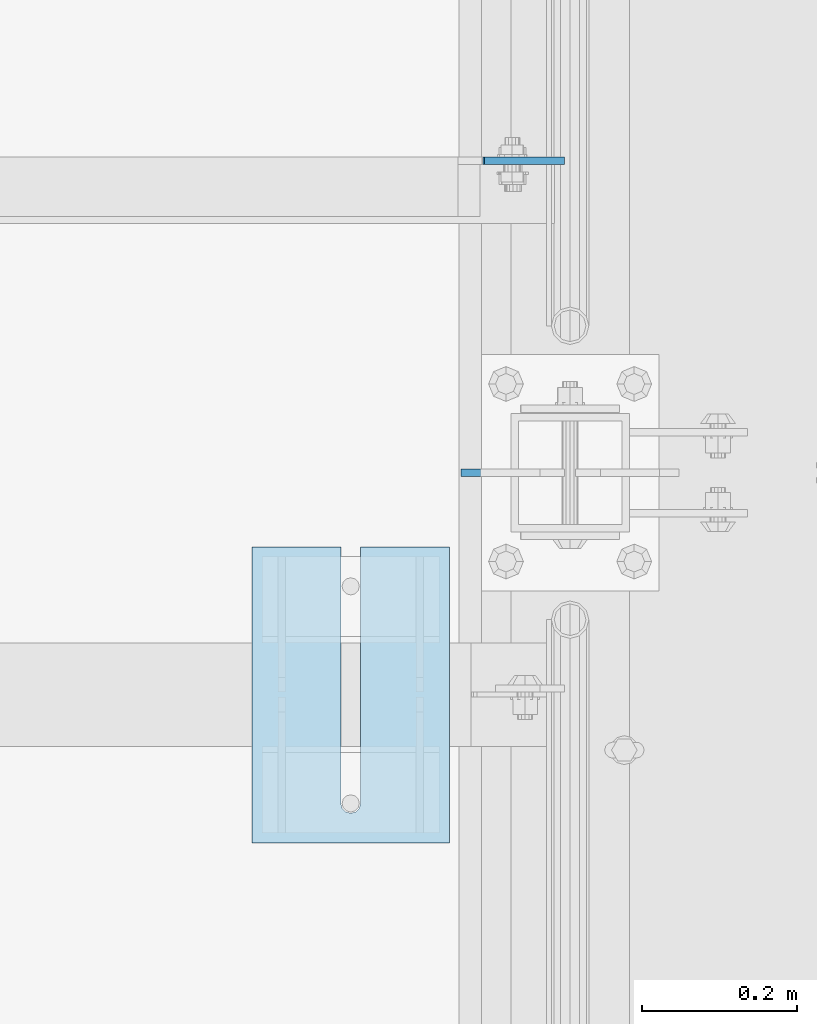
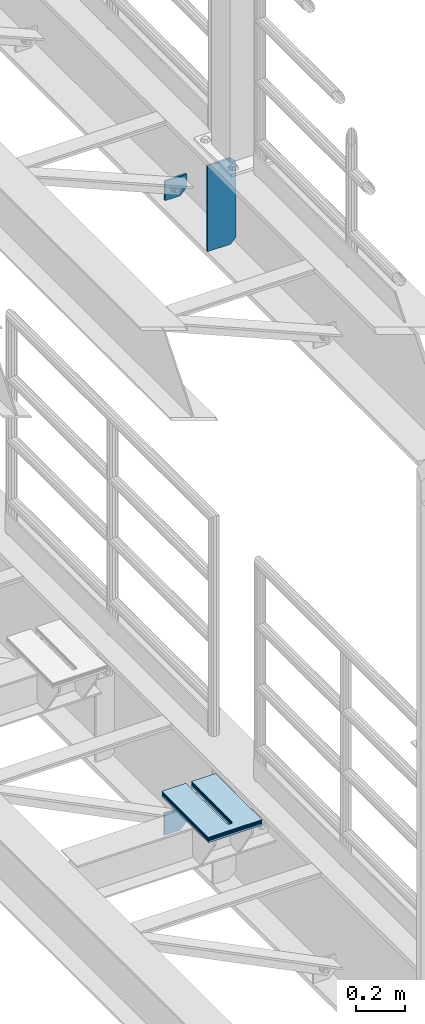
# One storey, part 1741 of 1876: 9 plates, 8 elements without a shape of their own.
"""IFC2X3 building model written with IfcOpenShell, lengths in millimetres."""

from ifc_helpers import new_model, si_unit, frame, origin_with_axes, place, context, subcontext, project, spatial, faceted_brep, material, type_object, element, aggregate, save


model = new_model("IFC2X3")

# Units and contexts
model_context = context("Model", 3, precision=1e-05, world=origin_with_axes())
body_context = subcontext(model_context, "Body", "Model", "MODEL_VIEW")
ifc_project = project(units=[si_unit("LENGTHUNIT", "METRE", prefix="MILLI"), si_unit("AREAUNIT", "SQUARE_METRE"), si_unit("VOLUMEUNIT", "CUBIC_METRE"), si_unit("MASSUNIT", "GRAM", prefix="KILO"), si_unit("TIMEUNIT", "SECOND"), si_unit("PLANEANGLEUNIT", "RADIAN"), si_unit("SOLIDANGLEUNIT", "STERADIAN"), si_unit("THERMODYNAMICTEMPERATUREUNIT", "DEGREE_CELSIUS"), si_unit("LUMINOUSINTENSITYUNIT", "LUMEN")], contexts=[model_context])

# Site, building, storey
site_placement = place(None, origin_with_axes())
site = spatial("IfcSite", under=ifc_project, at=site_placement, CompositionType="ELEMENT")
building_placement = place(site_placement, origin_with_axes())
building = spatial("IfcBuilding", under=site, at=building_placement, Name="Undefined", CompositionType="ELEMENT")
storey_placement = place(building_placement, origin_with_axes())
storey = spatial("IfcBuildingStorey", under=building, at=storey_placement, Name="Undefined", CompositionType="ELEMENT", Elevation=0.0)

# Assembly, plate
assembly_1_placement = place(storey_placement, origin_with_axes())
assembly_1 = element("IfcElementAssembly", 1, at=assembly_1_placement, inside=storey, Name="BEAM", AssemblyPlace="NOTDEFINED", PredefinedType="RIGID_FRAME")
ifc_material = material(Name="STEEL/A36")
plate_type_1 = type_object("IfcPlateType", PredefinedType="NOTDEFINED")
plate_1_placement = place(assembly_1_placement, frame((7612.85625316118, 10053.6375, 7797.57504945555), z_axis=(0.0, 0.0, -1.0), x_axis=(-1.0, 0.0, 0.0)))
plate_1 = element("IfcPlate", 2, at=plate_1_placement, type_object=plate_type_1, material=ifc_material, Name="PLATE", context=body_context, shape_type="Brep", body=[
    faceted_brep([(0.0, -4.76249999999982, 0.0), (1.09336269815685e-06, -4.76250000000073, 64.8625564575195), (1.09336269815685e-06, 4.76250000000073, 64.8625564575195), (0.0, 4.76249999999982, 0.0), (31.7500016285603, -4.76250000000073, 96.612556457525), (31.7500016285603, 4.76250000000073, 96.612556457525), (103.211387634261, -4.76250000000073, 96.6125564575368), (103.211387634261, 4.76250000000073, 96.6125564575368), (103.211395263672, -4.76250000000073, 5.18411980010569e-11), (103.211395263672, 4.76250000000073, 5.18411980010569e-11)], [[[0, 1, 2, 3]], [[1, 4, 5, 2]], [[4, 6, 7, 5]], [[6, 8, 9, 7]], [[8, 0, 3, 9]], [[5, 7, 9, 3, 2]], [[8, 6, 4, 1, 0]]]),
])

assembly_2_placement = place(storey_placement, origin_with_axes())
assembly_2 = element("IfcElementAssembly", 3, at=assembly_2_placement, inside=storey, Name="BEAM", AssemblyPlace="NOTDEFINED", PredefinedType="RIGID_FRAME")
plate_type_2 = type_object("IfcPlateType", PredefinedType="NOTDEFINED")
plate_2_placement = place(assembly_2_placement, frame((7508.12421935484, 10053.6375, 4642.47708062509), z_axis=(1.0, 0.0, 0.0), x_axis=(0.0, 0.0, -1.0)))
plate_2 = element("IfcPlate", 4, at=plate_2_placement, type_object=plate_type_2, material=ifc_material, Name="PLATE", context=body_context, shape_type="Brep", body=[
    faceted_brep([(0.0, -4.76249999999982, 0.0), (0.0, -4.76250000000073, 104.732025146484), (0.0, 4.76250000000073, 104.732025146484), (0.0, 4.76249999999982, 0.0), (76.8270874023438, -4.76250000000073, 104.732025146484), (76.8270874023438, 4.76250000000073, 104.732025146484), (108.577087402344, -4.76250000000073, 72.9820251464844), (108.577087402344, 4.76250000000073, 72.9820251464844), (108.577087402344, -4.76250000000073, 0.0), (108.577087402344, 4.76250000000073, 0.0)], [[[0, 1, 2, 3]], [[1, 4, 5, 2]], [[4, 6, 7, 5]], [[6, 8, 9, 7]], [[8, 0, 3, 9]], [[5, 7, 9, 3, 2]], [[8, 6, 4, 1, 0]]]),
])
aggregate(assembly_2, [plate_2])

assembly_3_placement = place(storey_placement, origin_with_axes())
assembly_3 = element("IfcElementAssembly", 5, at=assembly_3_placement, inside=storey, Name="SHIM PLATE", AssemblyPlace="NOTDEFINED", PredefinedType="RIGID_FRAME")
plate_type_3 = type_object("IfcPlateType", PredefinedType="NOTDEFINED")
plate_3_placement = place(assembly_3_placement, frame((7464.4258861702, 9556.41083578753, 5154.6115), z_axis=(0.0, -1.0, 0.0), x_axis=(-1.0, 0.0, 0.0)))
plate_3 = element("IfcPlate", 6, at=plate_3_placement, type_object=plate_type_3, material=ifc_material, Name="SHIM PLATE", context=body_context, shape_type="Brep", body=[
    faceted_brep([(114.225666651796, -1.58749999999964, 3.8198777474463e-11), (114.225666651796, 1.58749999999964, 3.8198777474463e-11), (114.225667968606, 1.58749999999964, 330.200590822098), (114.225667968606, -1.58749999999964, 330.200590822098), (115.927140877607, 1.58749999999964, 336.550596048311), (115.927140877607, -1.58749999999964, 336.550596048311), (120.575663766391, 1.58749999999964, 341.199123921255), (120.575663766391, -1.58749999999964, 341.199123921255), (126.925667168282, 1.58749999999964, 342.90060363874), (126.925667168282, -1.58749999999964, 342.90060363874), (133.275670733512, 1.58749999999964, 341.199124530865), (133.275670733512, -1.58749999999964, 341.199124530865), (137.924194068548, 1.58749999999964, 336.550597104191), (137.924194068548, -1.58749999999964, 336.550597104191), (139.625667587137, -1.58749999999964, 330.200592041319), (139.625667587137, 1.58749999999964, 330.200592041319), (139.625683436465, 1.58749999999964, 4.72937244921923e-11), (139.625683436465, -1.58749999999964, 4.72937244921923e-11), (9.09494701772928e-13, -1.58750000000146, 4.54747350886464e-13), (-1.83084230229724e-05, -1.58749999999964, 381.006103515625), (-1.83084230229724e-05, 1.58749999999964, 381.006103515625), (9.09494701772928e-13, 1.58750000000146, 4.54747350886464e-13), (253.999526977692, -1.58749999999964, 381.006103515754), (253.999526977692, 1.58749999999964, 381.006103515754), (253.999542236328, -1.58750000000146, 6.16182660451159e-11), (253.999542236328, 1.58750000000146, 6.16182660451159e-11)], [[[0, 1, 2, 3]], [[3, 2, 4, 5]], [[5, 4, 6, 7]], [[7, 6, 8, 9]], [[9, 8, 10, 11]], [[11, 10, 12, 13]], [[14, 15, 16, 17]], [[13, 12, 15, 14]], [[18, 19, 20, 21]], [[19, 22, 23, 20]], [[22, 24, 25, 23]], [[25, 24, 17, 16]], [[10, 8, 6, 4, 2, 1, 21, 20, 23, 25, 16, 15, 12]], [[18, 21, 1, 0]], [[24, 22, 19, 18, 0, 3, 5, 7, 9, 11, 13, 14, 17]]]),
])
aggregate(assembly_3, [plate_3])

assembly_4_placement = place(storey_placement, origin_with_axes())
assembly_4 = element("IfcElementAssembly", 7, at=assembly_4_placement, inside=storey, Name="SHIM PLATE", AssemblyPlace="NOTDEFINED", PredefinedType="RIGID_FRAME")
plate_4_placement = place(assembly_4_placement, frame((7464.4258861702, 9556.41081544306, 5151.4365), z_axis=(0.0, -1.0, 0.0), x_axis=(-1.0, 0.0, 0.0)))
plate_4 = element("IfcPlate", 8, at=plate_4_placement, type_object=plate_type_3, material=ifc_material, Name="SHIM PLATE", context=body_context, shape_type="Brep", body=[
    faceted_brep([(114.225666651796, -1.58749999999964, 3.8198777474463e-11), (114.225666651796, 1.58749999999964, 3.8198777474463e-11), (114.225667968606, 1.58749999999964, 330.200590822098), (114.225667968606, -1.58749999999964, 330.200590822098), (115.927140877607, 1.58749999999964, 336.550596048311), (115.927140877607, -1.58749999999964, 336.550596048311), (120.575663766391, 1.58749999999964, 341.199123921255), (120.575663766391, -1.58749999999964, 341.199123921255), (126.925667168282, 1.58749999999964, 342.90060363874), (126.925667168282, -1.58749999999964, 342.90060363874), (133.275670733512, 1.58749999999964, 341.199124530865), (133.275670733512, -1.58749999999964, 341.199124530865), (137.924194068548, 1.58749999999964, 336.550597104191), (137.924194068548, -1.58749999999964, 336.550597104191), (139.625667587137, -1.58749999999964, 330.200592041319), (139.625667587137, 1.58749999999964, 330.200592041319), (139.625683436465, 1.58749999999964, 4.72937244921923e-11), (139.625683436465, -1.58749999999964, 4.72937244921923e-11), (9.09494701772928e-13, -1.58750000000146, 4.54747350886464e-13), (-1.83084230229724e-05, -1.58749999999964, 381.006103515625), (-1.83084230229724e-05, 1.58749999999964, 381.006103515625), (9.09494701772928e-13, 1.58750000000146, 4.54747350886464e-13), (253.999526977692, -1.58749999999964, 381.006103515754), (253.999526977692, 1.58749999999964, 381.006103515754), (253.999542236328, -1.58750000000146, 6.16182660451159e-11), (253.999542236328, 1.58750000000146, 6.16182660451159e-11)], [[[0, 1, 2, 3]], [[3, 2, 4, 5]], [[5, 4, 6, 7]], [[7, 6, 8, 9]], [[9, 8, 10, 11]], [[11, 10, 12, 13]], [[14, 15, 16, 17]], [[13, 12, 15, 14]], [[18, 19, 20, 21]], [[19, 22, 23, 20]], [[22, 24, 25, 23]], [[25, 24, 17, 16]], [[10, 8, 6, 4, 2, 1, 21, 20, 23, 25, 16, 15, 12]], [[18, 21, 1, 0]], [[24, 22, 19, 18, 0, 3, 5, 7, 9, 11, 13, 14, 17]]]),
])
aggregate(assembly_4, [plate_4])

assembly_5_placement = place(storey_placement, origin_with_axes())
assembly_5 = element("IfcElementAssembly", 9, at=assembly_5_placement, inside=storey, Name="SHIM PLATE", AssemblyPlace="NOTDEFINED", PredefinedType="RIGID_FRAME")
plate_type_4 = type_object("IfcPlateType", PredefinedType="NOTDEFINED")
plate_5_placement = place(assembly_5_placement, frame((7464.4258861702, 9556.41085613199, 5156.9925), z_axis=(0.0, -1.0, 0.0), x_axis=(-1.0, 0.0, 0.0)))
plate_5 = element("IfcPlate", 10, at=plate_5_placement, type_object=plate_type_4, material=ifc_material, Name="SHIM PLATE", context=body_context, shape_type="Brep", body=[
    faceted_brep([(114.225666651797, -0.793499999999767, 3.8198777474463e-11), (114.225666651797, 0.793499999999767, 3.8198777474463e-11), (114.225667968606, 0.793499999999767, 330.200590822098), (114.225667968606, -0.793499999999767, 330.200590822098), (115.927140877607, 0.793499999999767, 336.550596048311), (115.927140877607, -0.793499999999767, 336.550596048311), (120.575663766392, 0.793499999999767, 341.199123921255), (120.575663766392, -0.793499999999767, 341.199123921255), (126.925667168282, 0.793499999999767, 342.90060363874), (126.925667168282, -0.793499999999767, 342.90060363874), (133.275670733513, 0.793499999999767, 341.199124530865), (133.275670733513, -0.793499999999767, 341.199124530865), (137.924194068548, 0.793499999999767, 336.550597104191), (137.924194068548, -0.793499999999767, 336.550597104191), (139.625667587137, -0.793499999999767, 330.200592041319), (139.625667587137, 0.793499999999767, 330.200592041319), (139.625683436465, 0.793499999999767, 4.72937244921923e-11), (139.625683436465, -0.793499999999767, 4.72937244921923e-11), (9.09494701772928e-13, -0.793499999999767, 0.0), (-1.83080774149857e-05, -0.793499999999767, 381.006103515625), (-1.83080774149857e-05, 0.793499999999767, 381.006103515625), (9.09494701772928e-13, 0.793499999999767, 0.0), (253.999526977692, -0.793499999999767, 381.006103515754), (253.999526977692, 0.793499999999767, 381.006103515754), (253.999542236328, -0.793499999999767, 6.16182660451159e-11), (253.999542236328, 0.793499999999767, 6.16182660451159e-11)], [[[0, 1, 2, 3]], [[3, 2, 4, 5]], [[5, 4, 6, 7]], [[7, 6, 8, 9]], [[9, 8, 10, 11]], [[11, 10, 12, 13]], [[14, 15, 16, 17]], [[13, 12, 15, 14]], [[18, 19, 20, 21]], [[19, 22, 23, 20]], [[22, 24, 25, 23]], [[25, 24, 17, 16]], [[10, 8, 6, 4, 2, 1, 21, 20, 23, 25, 16, 15, 12]], [[18, 21, 1, 0]], [[24, 22, 19, 18, 0, 3, 5, 7, 9, 11, 13, 14, 17]]]),
])
aggregate(assembly_5, [plate_5])

assembly_6_placement = place(storey_placement, origin_with_axes())
assembly_6 = element("IfcElementAssembly", 11, at=assembly_6_placement, inside=storey, Name="SHIM PLATE", AssemblyPlace="NOTDEFINED", PredefinedType="RIGID_FRAME")
plate_type_5 = type_object("IfcPlateType", PredefinedType="NOTDEFINED")
plate_6_placement = place(assembly_6_placement, frame((7464.4258861702, 9556.41079509859, 5147.468), z_axis=(0.0, -1.0, 0.0), x_axis=(-1.0, 0.0, 0.0)))
plate_6 = element("IfcPlate", 12, at=plate_6_placement, type_object=plate_type_5, material=ifc_material, Name="SHIM PLATE", context=body_context, shape_type="Brep", body=[
    faceted_brep([(114.225666651796, -2.38100000000031, 3.8198777474463e-11), (114.225666651796, 2.38100000000031, 3.8198777474463e-11), (114.225667968606, 2.38100000000031, 330.200590822098), (114.225667968606, -2.38100000000031, 330.200590822098), (115.927140877607, 2.38100000000031, 336.550596048311), (115.927140877607, -2.38100000000031, 336.550596048311), (120.575663766391, 2.38100000000031, 341.199123921255), (120.575663766391, -2.38100000000031, 341.199123921255), (126.925667168282, 2.38100000000031, 342.90060363874), (126.925667168282, -2.38100000000031, 342.90060363874), (133.275670733512, 2.38100000000031, 341.199124530865), (133.275670733512, -2.38100000000031, 341.199124530865), (137.924194068548, 2.38100000000031, 336.550597104191), (137.924194068548, -2.38100000000031, 336.550597104191), (139.625667587137, -2.38100000000031, 330.200592041319), (139.625667587137, 2.38100000000031, 330.200592041319), (139.625683436464, 2.38100000000031, 4.72937244921923e-11), (139.625683436464, -2.38100000000031, 4.72937244921923e-11), (0.0, -2.38100000000122, 4.54747350886464e-13), (-1.83087686309591e-05, -2.38100000000031, 381.006103515625), (-1.83087686309591e-05, 2.38100000000031, 381.006103515625), (0.0, 2.38100000000122, 4.54747350886464e-13), (253.999526977692, -2.38100000000031, 381.006103515754), (253.999526977692, 2.38100000000031, 381.006103515754), (253.999542236328, -2.38100000000122, 6.16182660451159e-11), (253.999542236328, 2.38100000000122, 6.16182660451159e-11)], [[[0, 1, 2, 3]], [[3, 2, 4, 5]], [[5, 4, 6, 7]], [[7, 6, 8, 9]], [[9, 8, 10, 11]], [[11, 10, 12, 13]], [[14, 15, 16, 17]], [[13, 12, 15, 14]], [[18, 19, 20, 21]], [[19, 22, 23, 20]], [[22, 24, 25, 23]], [[25, 24, 17, 16]], [[10, 8, 6, 4, 2, 1, 21, 20, 23, 25, 16, 15, 12]], [[18, 21, 1, 0]], [[24, 22, 19, 18, 0, 3, 5, 7, 9, 11, 13, 14, 17]]]),
])
aggregate(assembly_6, [plate_6])

assembly_7_placement = place(storey_placement, origin_with_axes())
assembly_7 = element("IfcElementAssembly", 13, at=assembly_7_placement, inside=storey, Name="SHIM PLATE", AssemblyPlace="NOTDEFINED", PredefinedType="RIGID_FRAME")
plate_7_placement = place(assembly_7_placement, frame((7464.4258861702, 9556.41077475413, 5142.706), z_axis=(0.0, -1.0, 0.0), x_axis=(-1.0, 0.0, 0.0)))
plate_7 = element("IfcPlate", 14, at=plate_7_placement, type_object=plate_type_5, material=ifc_material, Name="SHIM PLATE", context=body_context, shape_type="Brep", body=[
    faceted_brep([(114.225666651796, -2.38100000000031, 3.8198777474463e-11), (114.225666651796, 2.38100000000031, 3.8198777474463e-11), (114.225667968606, 2.38100000000031, 330.200590822098), (114.225667968606, -2.38100000000031, 330.200590822098), (115.927140877607, 2.38100000000031, 336.550596048311), (115.927140877607, -2.38100000000031, 336.550596048311), (120.575663766391, 2.38100000000031, 341.199123921255), (120.575663766391, -2.38100000000031, 341.199123921255), (126.925667168282, 2.38100000000031, 342.90060363874), (126.925667168282, -2.38100000000031, 342.90060363874), (133.275670733512, 2.38100000000031, 341.199124530865), (133.275670733512, -2.38100000000031, 341.199124530865), (137.924194068548, 2.38100000000031, 336.550597104191), (137.924194068548, -2.38100000000031, 336.550597104191), (139.625667587137, -2.38100000000031, 330.200592041319), (139.625667587137, 2.38100000000031, 330.200592041319), (139.625683436464, 2.38100000000031, 4.72937244921923e-11), (139.625683436464, -2.38100000000031, 4.72937244921923e-11), (0.0, -2.38100000000122, 4.54747350886464e-13), (-1.83087686309591e-05, -2.38100000000031, 381.006103515625), (-1.83087686309591e-05, 2.38100000000031, 381.006103515625), (0.0, 2.38100000000122, 4.54747350886464e-13), (253.999526977692, -2.38100000000031, 381.006103515754), (253.999526977692, 2.38100000000031, 381.006103515754), (253.999542236328, -2.38100000000122, 6.16182660451159e-11), (253.999542236328, 2.38100000000122, 6.16182660451159e-11)], [[[0, 1, 2, 3]], [[3, 2, 4, 5]], [[5, 4, 6, 7]], [[7, 6, 8, 9]], [[9, 8, 10, 11]], [[11, 10, 12, 13]], [[14, 15, 16, 17]], [[13, 12, 15, 14]], [[18, 19, 20, 21]], [[19, 22, 23, 20]], [[22, 24, 25, 23]], [[25, 24, 17, 16]], [[10, 8, 6, 4, 2, 1, 21, 20, 23, 25, 16, 15, 12]], [[18, 21, 1, 0]], [[24, 22, 19, 18, 0, 3, 5, 7, 9, 11, 13, 14, 17]]]),
])
aggregate(assembly_7, [plate_7])

assembly_8_placement = place(storey_placement, origin_with_axes())
assembly_8 = element("IfcElementAssembly", 15, at=assembly_8_placement, inside=storey, Name="SHIM PLATE", AssemblyPlace="NOTDEFINED", PredefinedType="RIGID_FRAME")
plate_type_6 = type_object("IfcPlateType", PredefinedType="NOTDEFINED")
plate_8_placement = place(assembly_8_placement, frame((7464.42588617021, 9556.41075440966, 5135.5625), z_axis=(0.0, -1.0, 0.0), x_axis=(-1.0, 0.0, 0.0)))
plate_8 = element("IfcPlate", 16, at=plate_8_placement, type_object=plate_type_6, material=ifc_material, Name="SHIM PLATE", context=body_context, shape_type="Brep", body=[
    faceted_brep([(114.225666651796, -4.76249999999982, 3.8198777474463e-11), (114.225666651796, 4.76249999999982, 3.8198777474463e-11), (114.225667968606, 4.76249999999982, 330.200590822098), (114.225667968606, -4.76249999999982, 330.200590822098), (115.927140877606, 4.76249999999982, 336.550596048311), (115.927140877606, -4.76249999999982, 336.550596048311), (120.575663766391, 4.76249999999982, 341.199123921255), (120.575663766391, -4.76249999999982, 341.199123921255), (126.925667168282, 4.76249999999982, 342.90060363874), (126.925667168282, -4.76249999999982, 342.90060363874), (133.275670733512, 4.76249999999982, 341.199124530865), (133.275670733512, -4.76249999999982, 341.199124530865), (137.924194068547, 4.76249999999982, 336.550597104191), (137.924194068547, -4.76249999999982, 336.550597104191), (139.625667587137, -4.76249999999982, 330.200592041319), (139.625667587137, 4.76249999999982, 330.200592041319), (139.625683436464, 4.76249999999982, 4.72937244921923e-11), (139.625683436464, -4.76249999999982, 4.72937244921923e-11), (0.0, -4.76249999999982, 0.0), (-1.83091142389458e-05, -4.76249999999982, 381.006103515625), (-1.83091142389458e-05, 4.76249999999982, 381.006103515625), (0.0, 4.76249999999982, 0.0), (253.999526977692, -4.76249999999982, 381.006103515754), (253.999526977692, 4.76249999999982, 381.006103515754), (253.999542236328, -4.76250000000073, 6.16182660451159e-11), (253.999542236328, 4.76250000000073, 6.16182660451159e-11)], [[[0, 1, 2, 3]], [[3, 2, 4, 5]], [[5, 4, 6, 7]], [[7, 6, 8, 9]], [[9, 8, 10, 11]], [[11, 10, 12, 13]], [[14, 15, 16, 17]], [[13, 12, 15, 14]], [[18, 19, 20, 21]], [[19, 22, 23, 20]], [[22, 24, 25, 23]], [[25, 24, 17, 16]], [[10, 8, 6, 4, 2, 1, 21, 20, 23, 25, 16, 15, 12]], [[18, 21, 1, 0]], [[24, 22, 19, 18, 0, 3, 5, 7, 9, 11, 13, 14, 17]]]),
])
aggregate(assembly_8, [plate_8])

# Plate
plate_type_7 = type_object("IfcPlateType", PredefinedType="NOTDEFINED")
plate_9_placement = place(assembly_1_placement, frame((7612.85625, 9652.0, 7700.9625), z_axis=(0.0, 0.0, 1.0), x_axis=(-1.0, 0.0, 0.0)))
plate_9 = element("IfcPlate", 17, at=plate_9_placement, type_object=plate_type_7, material=ifc_material, Name="PLATE", context=body_context, shape_type="Brep", body=[
    faceted_brep([(0.0, -4.76250000000073, 25.3999996185303), (0.0, -4.76250000000073, 403.22500038147), (0.0, 4.76250000000073, 403.22500038147), (0.0, 4.76250000000073, 25.3999996185303), (25.3999996185303, -4.76250000000073, 428.625), (25.3999996185303, 4.76250000000073, 428.625), (133.350006103516, -4.76250000000073, 428.625), (133.350006103516, 4.76250000000073, 428.625), (133.350006103516, -4.76250000000073, 0.0), (133.350006103516, 4.76250000000073, 0.0), (25.4000015258789, -4.76250000000073, 0.0), (25.4000015258789, 4.76250000000073, 0.0)], [[[0, 1, 2, 3]], [[1, 4, 5, 2]], [[4, 6, 7, 5]], [[6, 8, 9, 7]], [[8, 10, 11, 9]], [[10, 0, 3, 11]], [[5, 7, 9, 11, 3, 2]], [[10, 8, 6, 4, 1, 0]]]),
])

aggregate(assembly_1, [plate_1, plate_9])

save(model, "model.ifc")
